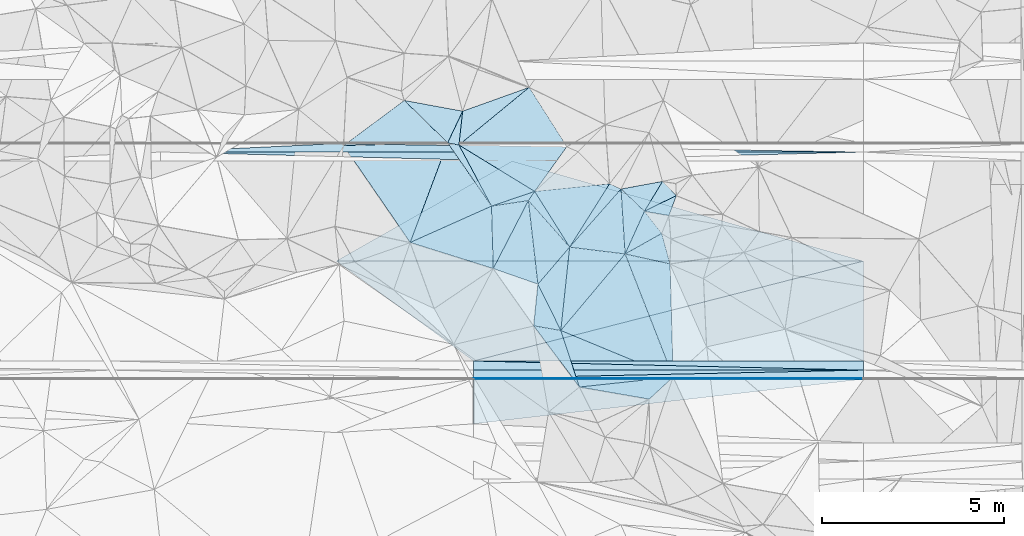
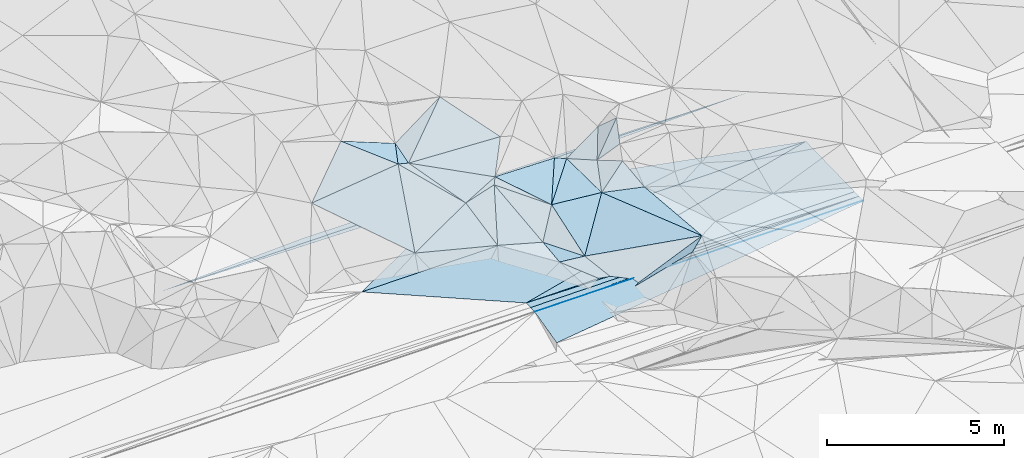
# One storey, part 50 of 275: 45 plates.
"""IFC2X3 building model written with IfcOpenShell, lengths in millimetres."""

from ifc_helpers import new_model, si_unit, frame, origin_with_axes, place, context, subcontext, project, spatial, polyline, outline, extrude, material, type_object, element, save


model = new_model("IFC2X3")

# Units and contexts
model_context = context("Model", 3, precision=1e-05, world=origin_with_axes())
body_context = subcontext(model_context, "Body", "Model", "MODEL_VIEW")
ifc_project = project(units=[si_unit("LENGTHUNIT", "METRE", prefix="MILLI"), si_unit("AREAUNIT", "SQUARE_METRE"), si_unit("VOLUMEUNIT", "CUBIC_METRE"), si_unit("MASSUNIT", "GRAM", prefix="KILO"), si_unit("TIMEUNIT", "SECOND"), si_unit("PLANEANGLEUNIT", "RADIAN"), si_unit("SOLIDANGLEUNIT", "STERADIAN"), si_unit("THERMODYNAMICTEMPERATUREUNIT", "DEGREE_CELSIUS"), si_unit("LUMINOUSINTENSITYUNIT", "LUMEN")], contexts=[model_context])

# Site, building, storey
site_placement = place(None, origin_with_axes())
site = spatial("IfcSite", under=ifc_project, at=site_placement, CompositionType="ELEMENT")
building_placement = place(site_placement, origin_with_axes())
building = spatial("IfcBuilding", under=site, at=building_placement, Name="Undefined", CompositionType="ELEMENT")
storey_placement = place(building_placement, origin_with_axes())
storey = spatial("IfcBuildingStorey", under=building, at=storey_placement, Name="Undefined", CompositionType="ELEMENT", Elevation=0.0)

# Plates
ifc_material = material()
plate_type_1 = type_object("IfcPlateType", PredefinedType="NOTDEFINED")
plate_1_placement = place(storey_placement, frame((-124610.502362477, 63294.0443863483, 49008.9291654633), z_axis=(0.008324340579686, 0.024990848492353, -0.999653021225638), x_axis=(0.999965340787191, -5.73519775278889e-05, 0.0083254990906575)))
element("IfcPlate", 1, at=plate_1_placement, inside=storey, type_object=plate_type_1, material=ifc_material, Name="00_PR", context=body_context, shape_type="SweptSolid", body=[
    extrude(outline(polyline([(0.0, 0.0), (14503.03515625, 1.02263584267348e-07), (3779.63134765625, 2750.85864257813), (0.0, 0.0)])), frame((-8.85201319254618e-08, 2.18876761149539e-07, -0.5000001331573), z_axis=(0.0, 0.0, 1.0), x_axis=(1.0, 0.0, 0.0)), (0.0, 0.0, 1.0), 1.0),
])
plate_2_placement = place(storey_placement, frame((-120830.587315527, 60543.8280489618, 48971.6511662542), z_axis=(0.008324340579686, 0.024990848492353, -0.999653021225638), x_axis=(0.968565278490692, 0.248349656151851, 0.0142740881147066)))
element("IfcPlate", 2, at=plate_2_placement, inside=storey, type_object=plate_type_1, material=ifc_material, Name="00_PR", context=body_context, shape_type="SweptSolid", body=[
    extrude(outline(polyline([(0.0, 0.0), (11070.619140625, -4.8195943236351e-08), (10386.5244140625, 2664.43994140625), (0.0, 0.0)])), frame((-8.85201319254618e-08, 2.18876761149539e-07, -0.5000001331573), z_axis=(0.0, 0.0, 1.0), x_axis=(1.0, 0.0, 0.0)), (0.0, 0.0, 1.0), 1.0),
])
plate_3_placement = place(storey_placement, frame((-119776.166734468, 66043.7427297711, 48980.4271662069), z_axis=(0.00832149793297365, -0.0249918019511436, -0.9996530210565), x_axis=(0.96172712039003, -0.273606547074793, 0.0148459861279161)))
element("IfcPlate", 3, at=plate_3_placement, inside=storey, type_object=plate_type_1, material=ifc_material, Name="00_PR", context=body_context, shape_type="SweptSolid", body=[
    extrude(outline(polyline([(0.0, 0.0), (10052.953125, -1.1648444342427e-07), (-3896.54565429688, 3968.56689453125), (0.0, 0.0)])), frame((-8.85201319254618e-08, 2.18876761149539e-07, -0.5000001331573), z_axis=(0.0, 0.0, 1.0), x_axis=(1.0, 0.0, 0.0)), (0.0, 0.0, 1.0), 1.0),
])
plate_type_2 = type_object("IfcPlateType", PredefinedType="NOTDEFINED")
plate_4_placement = place(storey_placement, frame((-110108.127132819, 60543.212590805, 49060.924166967), z_axis=(0.008324340579686, 0.024990848492353, -0.999653021225638), x_axis=(-5.72779639714365e-05, -0.999687644771442, -0.0249921909916474)))
element("IfcPlate", 4, at=plate_4_placement, inside=storey, type_object=plate_type_2, material=ifc_material, Name="00_PR", context=body_context, shape_type="SweptSolid", body=[
    extrude(outline(polyline([(0.0, 0.0), (250.078109741211, 1.02591002359986e-09), (2.2299907207489, 10722.83203125), (0.0, 0.0)])), frame((-8.85201319254618e-08, 2.18876761149539e-07, -0.5000001331573), z_axis=(0.0, 0.0, 1.0), x_axis=(1.0, 0.0, 0.0)), (0.0, 0.0, 1.0), 1.0),
])
plate_5_placement = place(storey_placement, frame((-110108.14145708, 60293.2125942532, 49054.6741678356), z_axis=(0.00832424080938101, 0.0250068329668296, -0.999652622324334), x_axis=(-0.999965344853481, 5.72919765649429e-05, -0.00832501109232228)))
element("IfcPlate", 5, at=plate_5_placement, inside=storey, type_object=plate_type_2, material=ifc_material, Name="00_PR", context=body_context, shape_type="SweptSolid", body=[
    extrude(outline(polyline([(0.0, 0.0), (10722.83203125, -5.55592123419046e-08), (10722.7802734375, 250.078216552734), (0.0, 0.0)])), frame((-8.85201319254618e-08, 2.18876761149539e-07, -0.5000001331573), z_axis=(0.0, 0.0, 1.0), x_axis=(1.0, 0.0, 0.0)), (0.0, 0.0, 1.0), 1.0),
])
plate_6_placement = place(storey_placement, frame((-129444.507635454, 66294.2964973411, 48893.6811645161), z_axis=(0.00832144820991533, -0.0249898612840356, -0.99965306998613), x_axis=(0.999965340787191, -5.73519775278889e-05, 0.0083254990906575)))
element("IfcPlate", 6, at=plate_6_placement, inside=storey, type_object=plate_type_2, material=ifc_material, Name="00_PR", context=body_context, shape_type="SweptSolid", body=[
    extrude(outline(polyline([(0.0, 0.0), (19337.380859375, 2.13287421502173e-07), (9668.7421875, 250.077438354492), (0.0, 0.0)])), frame((-8.85201319254618e-08, 2.18876761149539e-07, -0.5000001331573), z_axis=(0.0, 0.0, 1.0), x_axis=(1.0, 0.0, 0.0)), (0.0, 0.0, 1.0), 1.0),
])
plate_type_3 = type_object("IfcPlateType", PredefinedType="NOTDEFINED")
plate_7_placement = place(storey_placement, frame((-120830.61538651, 60063.8395127007, 48953.8976337332), z_axis=(0.00831835231018961, 0.0499346274362642, -0.998717847040717), x_axis=(0.999965340787191, -5.73519775278889e-05, 0.0083254990906575)))
element("IfcPlate", 7, at=plate_7_placement, inside=storey, type_object=plate_type_3, material=ifc_material, Name="00_PR", context=body_context, shape_type="SweptSolid", body=[
    extrude(outline(polyline([(0.0, 0.0), (10722.83203125, -5.55592123419046e-08), (10722.82421875, 20.0253067016602), (0.0, 0.0)])), frame((-8.85201319254618e-08, 2.18876761149539e-07, -0.5000001331573), z_axis=(0.0, 0.0, 1.0), x_axis=(1.0, 0.0, 0.0)), (0.0, 0.0, 1.0), 1.0),
])
plate_8_placement = place(storey_placement, frame((-110108.155782684, 60043.2248544637, 49042.1746248938), z_axis=(0.00831779862514196, 0.049539601639022, -0.998737524125072), x_axis=(-0.999965344853481, 5.72919765649429e-05, -0.00832501109232228)))
element("IfcPlate", 8, at=plate_8_placement, inside=storey, type_object=plate_type_3, material=ifc_material, Name="00_PR", context=body_context, shape_type="SweptSolid", body=[
    extrude(outline(polyline([(0.0, 0.0), (10722.83203125, -5.55592123419046e-08), (10722.82421875, 20.0235919952393), (0.0, 0.0)])), frame((-8.85201319254618e-08, 2.18876761149539e-07, -0.5000001331573), z_axis=(0.0, 0.0, 1.0), x_axis=(1.0, 0.0, 0.0)), (0.0, 0.0, 1.0), 1.0),
])
plate_type_4 = type_object("IfcPlateType", PredefinedType="NOTDEFINED")
plate_9_placement = place(storey_placement, frame((-110108.154697284, 60063.2253811609, 49043.1746351138), z_axis=(0.00831835231018961, 0.0499346274362642, -0.998717847040717), x_axis=(-0.999965344853481, 5.72919765649429e-05, -0.00832501109232228)))
element("IfcPlate", 9, at=plate_9_placement, inside=storey, type_object=plate_type_4, material=ifc_material, Name="00_PR", context=body_context, shape_type="SweptSolid", body=[
    extrude(outline(polyline([(0.0, 0.0), (10722.83203125, -5.55592123419046e-08), (-0.0958082377910614, 230.286972045898), (0.0, 0.0)])), frame((-8.85201319254618e-08, 2.18876761149539e-07, -0.5000001331573), z_axis=(0.0, 0.0, 1.0), x_axis=(1.0, 0.0, 0.0)), (0.0, 0.0, 1.0), 1.0),
])
plate_10_placement = place(storey_placement, frame((-120830.601646001, 60293.8405085212, 48965.3976334797), z_axis=(0.00831835231018961, 0.0499346274362642, -0.998717847040717), x_axis=(0.999965340787191, -5.73519775278889e-05, 0.0083254990906575)))
element("IfcPlate", 10, at=plate_10_placement, inside=storey, type_object=plate_type_4, material=ifc_material, Name="00_PR", context=body_context, shape_type="SweptSolid", body=[
    extrude(outline(polyline([(0.0, 0.0), (10722.83203125, -5.55592123419046e-08), (-0.0962902829051018, 230.288299560547), (0.0, 0.0)])), frame((-8.85201319254618e-08, 2.18876761149539e-07, -0.5000001331573), z_axis=(0.0, 0.0, 1.0), x_axis=(1.0, 0.0, 0.0)), (0.0, 0.0, 1.0), 1.0),
])
plate_11_placement = place(storey_placement, frame((-110107.797697008, 66293.1751613901, 49054.6746353648), z_axis=(0.00831224750610881, -0.0499379782776763, -0.998717730325709), x_axis=(-0.999965344853481, 5.72919765649429e-05, -0.00832501109232228)))
element("IfcPlate", 11, at=plate_11_placement, inside=storey, type_object=plate_type_4, material=ifc_material, Name="00_PR", context=body_context, shape_type="SweptSolid", body=[
    extrude(outline(polyline([(0.0, 0.0), (19337.380859375, 2.13287421502173e-07), (14503.130859375, 230.287124633789), (0.0, 0.0)])), frame((-8.85201319254618e-08, 2.18876761149539e-07, -0.5000001331573), z_axis=(0.0, 0.0, 1.0), x_axis=(1.0, 0.0, 0.0)), (0.0, 0.0, 1.0), 1.0),
])
plate_type_5 = type_object("IfcPlateType", PredefinedType="NOTDEFINED")
plate_12_placement = place(storey_placement, frame((-119325.093733109, 64958.7979424219, 49849.5225955544), z_axis=(0.066211966406673, 0.289808461752004, -0.954791616532895), x_axis=(0.652565308022866, -0.73645985067863, -0.178284623855879)))
element("IfcPlate", 12, at=plate_12_placement, inside=storey, type_object=plate_type_5, material=ifc_material, Name="00", context=body_context, shape_type="SweptSolid", body=[
    extrude(outline(polyline([(0.0, 0.0), (1738.79272460938, -3.34694050252438e-10), (1986.60827636719, 1369.66687011719), (0.0, 0.0)])), frame((-8.85201319254618e-08, 2.18876761149539e-07, -0.5000001331573), z_axis=(0.0, 0.0, 1.0), x_axis=(1.0, 0.0, 0.0)), (0.0, 0.0, 1.0), 1.0),
])
plate_type_6 = type_object("IfcPlateType", PredefinedType="NOTDEFINED")
plate_13_placement = place(storey_placement, frame((-121546.665615824, 66546.1144424768, 50379.5313573619), z_axis=(-0.0547410617611769, 0.344343148468041, -0.937246612296025), x_axis=(0.974375206189065, -0.186667956876011, -0.125491160803271)))
element("IfcPlate", 13, at=plate_13_placement, inside=storey, type_object=plate_type_6, material=ifc_material, Name="00", context=body_context, shape_type="SweptSolid", body=[
    extrude(outline(polyline([(0.0, 0.0), (318.74755859375, 6.03904481977224e-10), (1589.97302246094, 1569.23095703125), (0.0, 0.0)])), frame((-8.85201319254618e-08, 2.18876761149539e-07, -0.5000001331573), z_axis=(0.0, 0.0, 1.0), x_axis=(1.0, 0.0, 0.0)), (0.0, 0.0, 1.0), 1.0),
])
plate_type_7 = type_object("IfcPlateType", PredefinedType="NOTDEFINED")
plate_14_placement = place(storey_placement, frame((-116133.093025118, 64664.0184016748, 49759.6508206451), z_axis=(0.715528851747422, -0.0190819038643633, -0.69832252094711), x_axis=(0.46304293591163, 0.761444101335042, 0.453645368150507)))
element("IfcPlate", 14, at=plate_14_placement, inside=storey, type_object=plate_type_7, material=ifc_material, Name="00", context=body_context, shape_type="SweptSolid", body=[
    extrude(outline(polyline([(0.0, 0.0), (1080.13891601563, 5.29689714312553e-09), (1140.87182617188, 672.689758300781), (0.0, 0.0)])), frame((-8.85201319254618e-08, 2.18876761149539e-07, -0.5000001331573), z_axis=(0.0, 0.0, 1.0), x_axis=(1.0, 0.0, 0.0)), (0.0, 0.0, 1.0), 1.0),
])
plate_type_8 = type_object("IfcPlateType", PredefinedType="NOTDEFINED")
plate_15_placement = place(storey_placement, frame((-120830.687312707, 58815.2346338975, 48645.7449369341), z_axis=(0.0080904527200821, 0.242527248972756, -0.970110858655077), x_axis=(5.62409505467911e-05, 0.970142599249694, 0.242535222097746)))
element("IfcPlate", 15, at=plate_15_placement, inside=storey, type_object=plate_type_8, material=ifc_material, Name="00_PR", context=body_context, shape_type="SweptSolid", body=[
    extrude(outline(polyline([(0.0, 0.0), (1266.51708984375, -2.38651409745216e-09), (1288.17395019531, 10722.8095703125), (0.0, 0.0)])), frame((-8.85201319254618e-08, 2.18876761149539e-07, -0.5000001331573), z_axis=(0.0, 0.0, 1.0), x_axis=(1.0, 0.0, 0.0)), (0.0, 0.0, 1.0), 1.0),
])
plate_type_9 = type_object("IfcPlateType", PredefinedType="NOTDEFINED")
plate_16_placement = place(storey_placement, frame((-117091.49939466, 65421.3958546623, 49709.505641668), z_axis=(-0.0629014861596609, 0.136073393855939, -0.988699870801768), x_axis=(0.90287237307785, -0.414388060820088, -0.114472760875842)))
element("IfcPlate", 16, at=plate_16_placement, inside=storey, type_object=plate_type_9, material=ifc_material, Name="00", context=body_context, shape_type="SweptSolid", body=[
    extrude(outline(polyline([(0.0, 0.0), (349.428100585938, -4.64206095784903e-09), (-250.409164428711, 2052.50952148438), (0.0, 0.0)])), frame((-8.85201319254618e-08, 2.18876761149539e-07, -0.5000001331573), z_axis=(0.0, 0.0, 1.0), x_axis=(1.0, 0.0, 0.0)), (0.0, 0.0, 1.0), 1.0),
])
plate_type_10 = type_object("IfcPlateType", PredefinedType="NOTDEFINED")
plate_17_placement = place(storey_placement, frame((-115427.55023687, 63216.0212884442, 49469.5682371401), z_axis=(0.0618532587491814, 0.500524877992993, -0.86350971094262), x_axis=(-0.974894500019316, 0.2157152547801, 0.0552054588536712)))
element("IfcPlate", 17, at=plate_17_placement, inside=storey, type_object=plate_type_10, material=ifc_material, Name="00", context=body_context, shape_type="SweptSolid", body=[
    extrude(outline(polyline([(0.0, 0.0), (1267.99047851563, -5.28962118551135e-09), (430.050537109375, 890.200256347656), (0.0, 0.0)])), frame((-8.85201319254618e-08, 2.18876761149539e-07, -0.5000001331573), z_axis=(0.0, 0.0, 1.0), x_axis=(1.0, 0.0, 0.0)), (0.0, 0.0, 1.0), 1.0),
])
plate_type_11 = type_object("IfcPlateType", PredefinedType="NOTDEFINED")
plate_18_placement = place(storey_placement, frame((-116775.87064154, 65276.5711588291, 49669.5136918065), z_axis=(0.216642370821797, 0.0843505736027305, -0.972600156229476), x_axis=(0.720125798164282, -0.686472310904861, 0.100869228108457)))
element("IfcPlate", 18, at=plate_18_placement, inside=storey, type_object=plate_type_11, material=ifc_material, Name="00", context=body_context, shape_type="SweptSolid", body=[
    extrude(outline(polyline([(0.0, 0.0), (892.244384765625, 4.48926584795117e-09), (1294.60046386719, 1244.06970214844), (0.0, 0.0)])), frame((-8.85201319254618e-08, 2.18876761149539e-07, -0.5000001331573), z_axis=(0.0, 0.0, 1.0), x_axis=(1.0, 0.0, 0.0)), (0.0, 0.0, 1.0), 1.0),
])
plate_type_12 = type_object("IfcPlateType", PredefinedType="NOTDEFINED")
plate_19_placement = place(storey_placement, frame((-116663.733641182, 63489.332487826, 49539.5013407778), z_axis=(0.00904118606762447, 0.0731083068044699, -0.997283025239412), x_axis=(-0.992439676174179, 0.122733406843003, -2.11121228579398e-10)))
element("IfcPlate", 19, at=plate_19_placement, inside=storey, type_object=plate_type_12, material=ifc_material, Name="00", context=body_context, shape_type="SweptSolid", body=[
    extrude(outline(polyline([(0.0, 0.0), (1538.34326171875, -8.79663275554776e-09), (330.745422363281, 1764.74011230469), (0.0, 0.0)])), frame((-8.85201319254618e-08, 2.18876761149539e-07, -0.5000001331573), z_axis=(0.0, 0.0, 1.0), x_axis=(1.0, 0.0, 0.0)), (0.0, 0.0, 1.0), 1.0),
])
plate_type_13 = type_object("IfcPlateType", PredefinedType="NOTDEFINED")
plate_20_placement = place(storey_placement, frame((-121546.760462126, 66546.0221391505, 50379.5217716897), z_axis=(-0.244435305868527, 0.159737043963881, -0.956418035186832), x_axis=(-0.685034322359886, 0.669632130091373, 0.286915993869674)))
element("IfcPlate", 20, at=plate_20_placement, inside=storey, type_object=plate_type_13, material=ifc_material, Name="00", context=body_context, shape_type="SweptSolid", body=[
    extrude(outline(polyline([(0.0, 0.0), (1742.67041015625, 5.52245182916522e-09), (312.107208251953, 913.230041503906), (0.0, 0.0)])), frame((-8.85201319254618e-08, 2.18876761149539e-07, -0.5000001331573), z_axis=(0.0, 0.0, 1.0), x_axis=(1.0, 0.0, 0.0)), (0.0, 0.0, 1.0), 1.0),
])
plate_type_14 = type_object("IfcPlateType", PredefinedType="NOTDEFINED")
plate_21_placement = place(storey_placement, frame((-121236.032806877, 66486.6389579041, 50339.5409918523), z_axis=(0.0514480909433046, 0.393278622209551, -0.91797876840984), x_axis=(0.839879183112936, -0.514366198870355, -0.173292732776682)))
element("IfcPlate", 21, at=plate_21_placement, inside=storey, type_object=plate_type_14, material=ifc_material, Name="00", context=body_context, shape_type="SweptSolid", body=[
    extrude(outline(polyline([(0.0, 0.0), (2481.35034179688, -9.17862053029239e-09), (1733.61242675781, 1035.89953613281), (0.0, 0.0)])), frame((-8.85201319254618e-08, 2.18876761149539e-07, -0.5000001331573), z_axis=(0.0, 0.0, 1.0), x_axis=(1.0, 0.0, 0.0)), (0.0, 0.0, 1.0), 1.0),
])
plate_type_15 = type_object("IfcPlateType", PredefinedType="NOTDEFINED")
plate_22_placement = place(storey_placement, frame((-119179.551573836, 61513.4325413866, 49219.521852626), z_axis=(0.0746911852359752, 0.282819372774868, -0.956260649211958), x_axis=(0.984945082818069, -0.170838974789615, 0.0264050852174407)))
element("IfcPlate", 22, at=plate_22_placement, inside=storey, type_object=plate_type_15, material=ifc_material, Name="00", context=body_context, shape_type="SweptSolid", body=[
    extrude(outline(polyline([(0.0, 0.0), (757.429870605469, -4.15457179769874e-09), (1517.10412597656, 1510.56115722656), (0.0, 0.0)])), frame((-8.85201319254618e-08, 2.18876761149539e-07, -0.5000001331573), z_axis=(0.0, 0.0, 1.0), x_axis=(1.0, 0.0, 0.0)), (0.0, 0.0, 1.0), 1.0),
])
plate_type_16 = type_object("IfcPlateType", PredefinedType="NOTDEFINED")
plate_23_placement = place(storey_placement, frame((-124411.041466209, 66471.5840694024, 50079.5581231795), z_axis=(0.0805481094220166, 0.461044029652685, -0.883713983588668), x_axis=(0.749202544692307, 0.55676534906545, 0.358758823036591)))
element("IfcPlate", 23, at=plate_23_placement, inside=storey, type_object=plate_type_16, material=ifc_material, Name="00", context=body_context, shape_type="SweptSolid", body=[
    extrude(outline(polyline([(0.0, 0.0), (2229.91040039063, 3.05590219795704e-09), (2295.20434570313, 1741.44677734375), (0.0, 0.0)])), frame((-8.85201319254618e-08, 2.18876761149539e-07, -0.5000001331573), z_axis=(0.0, 0.0, 1.0), x_axis=(1.0, 0.0, 0.0)), (0.0, 0.0, 1.0), 1.0),
])
plate_type_17 = type_object("IfcPlateType", PredefinedType="NOTDEFINED")
plate_24_placement = place(storey_placement, frame((-118265.247324331, 66444.1957557585, 50239.5197992074), z_axis=(-0.0283718773315375, 0.277231736320905, -0.96038409032698), x_axis=(-0.570298220555847, -0.793549529743997, -0.212224134993916)))
element("IfcPlate", 24, at=plate_24_placement, inside=storey, type_object=plate_type_17, material=ifc_material, Name="00", context=body_context, shape_type="SweptSolid", body=[
    extrude(outline(polyline([(0.0, 0.0), (1554.95983886719, 1.07684172689915e-08), (1639.39929199219, 2479.91333007813), (0.0, 0.0)])), frame((-8.85201319254618e-08, 2.18876761149539e-07, -0.5000001331573), z_axis=(0.0, 0.0, 1.0), x_axis=(1.0, 0.0, 0.0)), (0.0, 0.0, 1.0), 1.0),
])
plate_type_18 = type_object("IfcPlateType", PredefinedType="NOTDEFINED")
plate_25_placement = place(storey_placement, frame((-116663.556073959, 63489.3009321919, 49539.534354562), z_axis=(0.364181895290088, 0.0100101350827713, -0.931274043629771), x_axis=(0.405568333011107, 0.898445107584856, 0.168257885150829)))
element("IfcPlate", 25, at=plate_25_placement, inside=storey, type_object=plate_type_18, material=ifc_material, Name="00", context=body_context, shape_type="SweptSolid", body=[
    extrude(outline(polyline([(0.0, 0.0), (1307.51672363281, -2.12457962334156e-09), (984.002685546875, 725.492004394531), (0.0, 0.0)])), frame((-8.85201319254618e-08, 2.18876761149539e-07, -0.5000001331573), z_axis=(0.0, 0.0, 1.0), x_axis=(1.0, 0.0, 0.0)), (0.0, 0.0, 1.0), 1.0),
])
plate_type_19 = type_object("IfcPlateType", PredefinedType="NOTDEFINED")
plate_26_placement = place(storey_placement, frame((-119152.025029337, 65210.2362615342, 49909.5138124331), z_axis=(-0.00215097992596716, 0.233485643640575, -0.97235787007619), x_axis=(0.52082784441825, -0.82980433821746, -0.200407376995266)))
element("IfcPlate", 26, at=plate_26_placement, inside=storey, type_object=plate_type_19, material=ifc_material, Name="00", context=body_context, shape_type="SweptSolid", body=[
    extrude(outline(polyline([(0.0, 0.0), (1846.23937988281, 5.60976332053542e-09), (130.535614013672, 282.4189453125), (0.0, 0.0)])), frame((-8.85201319254618e-08, 2.18876761149539e-07, -0.5000001331573), z_axis=(0.0, 0.0, 1.0), x_axis=(1.0, 0.0, 0.0)), (0.0, 0.0, 1.0), 1.0),
])
plate_type_20 = type_object("IfcPlateType", PredefinedType="NOTDEFINED")
plate_27_placement = place(storey_placement, frame((-118433.55418538, 61383.9565814811, 49239.5041673636), z_axis=(0.0158288827857986, 0.127994584769335, -0.99164854295233), x_axis=(0.104497458809963, 0.986129862443978, 0.128950283049246)))
element("IfcPlate", 27, at=plate_27_placement, inside=storey, type_object=plate_type_20, material=ifc_material, Name="00", context=body_context, shape_type="SweptSolid", body=[
    extrude(outline(polyline([(0.0, 0.0), (2326.47802734375, -6.22821971774101e-09), (2299.82836914063, 1538.11242675781), (0.0, 0.0)])), frame((-8.85201319254618e-08, 2.18876761149539e-07, -0.5000001331573), z_axis=(0.0, 0.0, 1.0), x_axis=(1.0, 0.0, 0.0)), (0.0, 0.0, 1.0), 1.0),
])
plate_type_21 = type_object("IfcPlateType", PredefinedType="NOTDEFINED")
plate_28_placement = place(storey_placement, frame((-119062.579258319, 62658.5185209833, 49169.522063369), z_axis=(0.054350700857574, 0.288769086901119, -0.955854808936266), x_axis=(-0.942901871517309, 0.32987295897065, 0.0460422808851249)))
element("IfcPlate", 28, at=plate_28_placement, inside=storey, type_object=plate_type_21, material=ifc_material, Name="00", context=body_context, shape_type="SweptSolid", body=[
    extrude(outline(polyline([(0.0, 0.0), (1303.15002441406, -8.92032403498888e-09), (1037.63952636719, 2178.50952148438), (0.0, 0.0)])), frame((-8.85201319254618e-08, 2.18876761149539e-07, -0.5000001331573), z_axis=(0.0, 0.0, 1.0), x_axis=(1.0, 0.0, 0.0)), (0.0, 0.0, 1.0), 1.0),
])
plate_type_22 = type_object("IfcPlateType", PredefinedType="NOTDEFINED")
plate_29_placement = place(storey_placement, frame((-118433.414813702, 61383.9391662039, 49239.5244436526), z_axis=(0.294568313296682, 0.0931523621219417, -0.951079463679377), x_axis=(-0.442058215299041, 0.895636456230213, -0.0491922001745405)))
element("IfcPlate", 29, at=plate_29_placement, inside=storey, type_object=plate_type_22, material=ifc_material, Name="00", context=body_context, shape_type="SweptSolid", body=[
    extrude(outline(polyline([(0.0, 0.0), (1422.98986816406, -1.76078174263239e-09), (1932.55078125, 1295.27905273438), (0.0, 0.0)])), frame((-8.85201319254618e-08, 2.18876761149539e-07, -0.5000001331573), z_axis=(0.0, 0.0, 1.0), x_axis=(1.0, 0.0, 0.0)), (0.0, 0.0, 1.0), 1.0),
])
plate_type_23 = type_object("IfcPlateType", PredefinedType="NOTDEFINED")
plate_30_placement = place(storey_placement, frame((-120339.683418775, 64805.3605008986, 49669.5101215499), z_axis=(0.154557836693083, 0.127372524662643, -0.979738799414323), x_axis=(0.929680037747538, 0.316867850104629, 0.187855777083929)))
element("IfcPlate", 30, at=plate_30_placement, inside=storey, type_object=plate_type_23, material=ifc_material, Name="00", context=body_context, shape_type="SweptSolid", body=[
    extrude(outline(polyline([(0.0, 0.0), (1277.57580566406, 4.17639967054129e-09), (1025.69250488281, 182.632995605469), (0.0, 0.0)])), frame((-8.85201319254618e-08, 2.18876761149539e-07, -0.5000001331573), z_axis=(0.0, 0.0, 1.0), x_axis=(1.0, 0.0, 0.0)), (0.0, 0.0, 1.0), 1.0),
])
plate_type_24 = type_object("IfcPlateType", PredefinedType="NOTDEFINED")
plate_31_placement = place(storey_placement, frame((-122576.486897287, 63805.6334441782, 49329.5160728864), z_axis=(0.0358091539897892, 0.249021091751864, -0.967835833369092), x_axis=(0.904283208720706, 0.40419974308369, 0.137457070086854)))
element("IfcPlate", 31, at=plate_31_placement, inside=storey, type_object=plate_type_24, material=ifc_material, Name="00", context=body_context, shape_type="SweptSolid", body=[
    extrude(outline(polyline([(0.0, 0.0), (2473.49951171875, 4.56930138170719e-09), (1762.765625, 1624.517578125), (0.0, 0.0)])), frame((-8.85201319254618e-08, 2.18876761149539e-07, -0.5000001331573), z_axis=(0.0, 0.0, 1.0), x_axis=(1.0, 0.0, 0.0)), (0.0, 0.0, 1.0), 1.0),
])
plate_type_25 = type_object("IfcPlateType", PredefinedType="NOTDEFINED")
plate_32_placement = place(storey_placement, frame((-115342.149849025, 60104.377194819, 49639.5698029977), z_axis=(0.316407381633033, -0.399543881177956, -0.860378437585104), x_axis=(-0.734323527940562, -0.677339832206832, 0.0444939099085128)))
element("IfcPlate", 32, at=plate_32_placement, inside=storey, type_object=plate_type_25, material=ifc_material, Name="00", context=body_context, shape_type="SweptSolid", body=[
    extrude(outline(polyline([(0.0, 0.0), (898.999450683594, 4.08908817917109e-09), (2044.05017089844, 1794.22924804688), (0.0, 0.0)])), frame((-8.85201319254618e-08, 2.18876761149539e-07, -0.5000001331573), z_axis=(0.0, 0.0, 1.0), x_axis=(1.0, 0.0, 0.0)), (0.0, 0.0, 1.0), 1.0),
])
plate_type_26 = type_object("IfcPlateType", PredefinedType="NOTDEFINED")
plate_33_placement = place(storey_placement, frame((-121235.918569406, 66486.4681206944, 50339.5206653885), z_axis=(0.279934771929813, 0.0516074239456176, -0.958630897300051), x_axis=(0.108892167807436, 0.990402826945736, 0.0851160159317348)))
element("IfcPlate", 33, at=plate_33_placement, inside=storey, type_object=plate_type_26, material=ifc_material, Name="00", context=body_context, shape_type="SweptSolid", body=[
    extrude(outline(polyline([(0.0, 0.0), (939.893615722656, -1.87719706445932e-09), (1837.86755371094, 1817.06982421875), (0.0, 0.0)])), frame((-8.85201319254618e-08, 2.18876761149539e-07, -0.5000001331573), z_axis=(0.0, 0.0, 1.0), x_axis=(1.0, 0.0, 0.0)), (0.0, 0.0, 1.0), 1.0),
])
plate_type_27 = type_object("IfcPlateType", PredefinedType="NOTDEFINED")
plate_34_placement = place(storey_placement, frame((-121133.765900852, 67417.3641021398, 50419.5053221043), z_axis=(-0.108834709776785, 0.0969887895225073, -0.989317027375331), x_axis=(-0.108892167821664, -0.990402826945935, -0.0851160159112202)))
element("IfcPlate", 34, at=plate_34_placement, inside=storey, type_object=plate_type_27, material=ifc_material, Name="00", context=body_context, shape_type="SweptSolid", body=[
    extrude(outline(polyline([(0.0, 0.0), (939.893615722656, -1.87719706445932e-09), (911.379760742188, 317.469635009766), (0.0, 0.0)])), frame((-8.85201319254618e-08, 2.18876761149539e-07, -0.5000001331573), z_axis=(0.0, 0.0, 1.0), x_axis=(1.0, 0.0, 0.0)), (0.0, 0.0, 1.0), 1.0),
])
plate_type_28 = type_object("IfcPlateType", PredefinedType="NOTDEFINED")
plate_35_placement = place(storey_placement, frame((-117920.692207946, 59828.5525779845, 48819.5452592751), z_axis=(0.253947426768248, 0.329267678791098, -0.909446809957189), x_axis=(-0.3032495650492, 0.919966112507811, 0.248398979737712)))
element("IfcPlate", 35, at=plate_35_placement, inside=storey, type_object=plate_type_28, material=ifc_material, Name="00", context=body_context, shape_type="SweptSolid", body=[
    extrude(outline(polyline([(0.0, 0.0), (1690.82824707031, -3.79804987460375e-09), (-324.160675048828, 2700.4296875), (0.0, 0.0)])), frame((-8.85201319254618e-08, 2.18876761149539e-07, -0.5000001331573), z_axis=(0.0, 0.0, 1.0), x_axis=(1.0, 0.0, 0.0)), (0.0, 0.0, 1.0), 1.0),
])
plate_type_29 = type_object("IfcPlateType", PredefinedType="NOTDEFINED")
plate_36_placement = place(storey_placement, frame((-115342.238876759, 60104.589353787, 49639.5049479321), z_axis=(0.138362456978983, 0.0247669370759464, -0.990071931390147), x_axis=(-0.917463808881891, 0.379692437779503, -0.118717362188485)))
element("IfcPlate", 36, at=plate_36_placement, inside=storey, type_object=plate_type_29, material=ifc_material, Name="00", context=body_context, shape_type="SweptSolid", body=[
    extrude(outline(polyline([(0.0, 0.0), (3369.34716796875, -5.37693267688155e-09), (2509.38818359375, 2629.72827148438), (0.0, 0.0)])), frame((-8.85201319254618e-08, 2.18876761149539e-07, -0.5000001331573), z_axis=(0.0, 0.0, 1.0), x_axis=(1.0, 0.0, 0.0)), (0.0, 0.0, 1.0), 1.0),
])
plate_type_30 = type_object("IfcPlateType", PredefinedType="NOTDEFINED")
plate_37_placement = place(storey_placement, frame((-119062.596995141, 62658.3513707881, 49169.5005909317), z_axis=(0.018877104369261, -0.0455403632812358, -0.998784125946566), x_axis=(0.442058215297751, -0.895636456230992, 0.0491922001719633)))
element("IfcPlate", 37, at=plate_37_placement, inside=storey, type_object=plate_type_30, material=ifc_material, Name="00", context=body_context, shape_type="SweptSolid", body=[
    extrude(outline(polyline([(0.0, 0.0), (1422.98986816406, -1.76078174263239e-09), (976.324645996094, 611.710876464844), (0.0, 0.0)])), frame((-8.85201319254618e-08, 2.18876761149539e-07, -0.5000001331573), z_axis=(0.0, 0.0, 1.0), x_axis=(1.0, 0.0, 0.0)), (0.0, 0.0, 1.0), 1.0),
])
plate_type_31 = type_object("IfcPlateType", PredefinedType="NOTDEFINED")
plate_38_placement = place(storey_placement, frame((-118190.507120944, 63678.1851589308, 49539.5101366588), z_axis=(-0.112128588919325, 0.166229153643388, -0.979691302414166), x_axis=(-0.520827844391641, 0.82980433825455, 0.200407376910846)))
element("IfcPlate", 38, at=plate_38_placement, inside=storey, type_object=plate_type_31, material=ifc_material, Name="00", context=body_context, shape_type="SweptSolid", body=[
    extrude(outline(polyline([(0.0, 0.0), (1846.23937988281, 5.60976332053542e-09), (908.224548339844, 1857.58666992188), (0.0, 0.0)])), frame((-8.85201319254618e-08, 2.18876761149539e-07, -0.5000001331573), z_axis=(0.0, 0.0, 1.0), x_axis=(1.0, 0.0, 0.0)), (0.0, 0.0, 1.0), 1.0),
])
plate_type_32 = type_object("IfcPlateType", PredefinedType="NOTDEFINED")
plate_39_placement = place(storey_placement, frame((-120291.282803755, 63088.3728714237, 49229.520351526), z_axis=(0.13245863636782, 0.249548569218346, -0.959260246884366), x_axis=(-0.0273020291982286, 0.968339252508485, 0.248140466778331)))
element("IfcPlate", 39, at=plate_39_placement, inside=storey, type_object=plate_type_32, material=ifc_material, Name="00", context=body_context, shape_type="SweptSolid", body=[
    extrude(outline(polyline([(0.0, 0.0), (1773.18920898438, 4.22005541622639e-09), (1938.65380859375, 1028.60168457031), (0.0, 0.0)])), frame((-8.85201319254618e-08, 2.18876761149539e-07, -0.5000001331573), z_axis=(0.0, 0.0, 1.0), x_axis=(1.0, 0.0, 0.0)), (0.0, 0.0, 1.0), 1.0),
])
plate_type_33 = type_object("IfcPlateType", PredefinedType="NOTDEFINED")
plate_40_placement = place(storey_placement, frame((-124411.036716085, 66471.5168735828, 50079.5295573016), z_axis=(0.0900312578109312, 0.32665232460906, -0.940846762998353), x_axis=(0.994226915809279, 0.0258891881834163, 0.104127757181132)))
element("IfcPlate", 40, at=plate_40_placement, inside=storey, type_object=plate_type_33, material=ifc_material, Name="00", context=body_context, shape_type="SweptSolid", body=[
    extrude(outline(polyline([(0.0, 0.0), (2881.076171875, 5.3987605497241e-09), (1676.87341308594, 2867.57666015625), (0.0, 0.0)])), frame((-8.85201319254618e-08, 2.18876761149539e-07, -0.5000001331573), z_axis=(0.0, 0.0, 1.0), x_axis=(1.0, 0.0, 0.0)), (0.0, 0.0, 1.0), 1.0),
])
plate_type_34 = type_object("IfcPlateType", PredefinedType="NOTDEFINED")
plate_41_placement = place(storey_placement, frame((-121236.071027503, 66486.6447015194, 50339.5429424009), z_axis=(-0.0249935907921863, 0.404768274903848, -0.914077657560164), x_axis=(0.748041533176964, 0.614150329434653, 0.251501963208173)))
element("IfcPlate", 41, at=plate_41_placement, inside=storey, type_object=plate_type_34, material=ifc_material, Name="00", context=body_context, shape_type="SweptSolid", body=[
    extrude(outline(polyline([(0.0, 0.0), (2584.47290039063, 1.23982317745686e-08), (2171.11962890625, 2030.72375488281), (0.0, 0.0)])), frame((-8.85201319254618e-08, 2.18876761149539e-07, -0.5000001331573), z_axis=(0.0, 0.0, 1.0), x_axis=(1.0, 0.0, 0.0)), (0.0, 0.0, 1.0), 1.0),
])
plate_type_35 = type_object("IfcPlateType", PredefinedType="NOTDEFINED")
plate_42_placement = place(storey_placement, frame((-115342.342486492, 60104.5488112423, 49639.5019650099), z_axis=(-0.0688628380623556, -0.0563122037913337, -0.996035564243647), x_axis=(-0.363539577190765, 0.931172442021103, -0.0275110711608269)))
element("IfcPlate", 42, at=plate_42_placement, inside=storey, type_object=plate_type_35, material=ifc_material, Name="00", context=body_context, shape_type="SweptSolid", body=[
    extrude(outline(polyline([(0.0, 0.0), (3634.900390625, -2.6775524020195e-09), (2932.73510742188, 1055.82397460938), (0.0, 0.0)])), frame((-8.85201319254618e-08, 2.18876761149539e-07, -0.5000001331573), z_axis=(0.0, 0.0, 1.0), x_axis=(1.0, 0.0, 0.0)), (0.0, 0.0, 1.0), 1.0),
])
plate_type_36 = type_object("IfcPlateType", PredefinedType="NOTDEFINED")
plate_43_placement = place(storey_placement, frame((-115633.103967128, 65486.6347723881, 50249.5623514907), z_axis=(0.392281379615959, 0.28290299903637, -0.8752606539442), x_axis=(-0.463042935915997, -0.76144410133132, -0.453645368152296)))
element("IfcPlate", 43, at=plate_43_placement, inside=storey, type_object=plate_type_36, material=ifc_material, Name="00", context=body_context, shape_type="SweptSolid", body=[
    extrude(outline(polyline([(0.0, 0.0), (1080.13891601563, 5.29689714312553e-09), (952.099792480469, 883.009643554688), (0.0, 0.0)])), frame((-8.85201319254618e-08, 2.18876761149539e-07, -0.5000001331573), z_axis=(0.0, 0.0, 1.0), x_axis=(1.0, 0.0, 0.0)), (0.0, 0.0, 1.0), 1.0),
])
plate_type_37 = type_object("IfcPlateType", PredefinedType="NOTDEFINED")
plate_44_placement = place(storey_placement, frame((-115253.054182104, 65097.0978995786, 50649.636130897), z_axis=(0.510667976191055, 0.457894191713468, -0.727702636581731), x_axis=(-0.268332375826946, -0.719228447341633, -0.640865178190866)))
element("IfcPlate", 44, at=plate_44_placement, inside=storey, type_object=plate_type_37, material=ifc_material, Name="00", context=body_context, shape_type="SweptSolid", body=[
    extrude(outline(polyline([(0.0, 0.0), (764.591369628906, 1.33877620100975e-09), (1117.85192871094, 710.286560058594), (0.0, 0.0)])), frame((-8.85201319254618e-08, 2.18876761149539e-07, -0.5000001331573), z_axis=(0.0, 0.0, 1.0), x_axis=(1.0, 0.0, 0.0)), (0.0, 0.0, 1.0), 1.0),
])
plate_type_38 = type_object("IfcPlateType", PredefinedType="NOTDEFINED")
plate_45_placement = place(storey_placement, frame((-121546.649019392, 66546.1246499439, 50379.5345530643), z_axis=(-0.0215428875755658, 0.364753900335402, -0.930854712715695), x_axis=(0.540245522237848, -0.779180885996558, -0.317823728817679)))
element("IfcPlate", 45, at=plate_45_placement, inside=storey, type_object=plate_type_38, material=ifc_material, Name="00", context=body_context, shape_type="SweptSolid", body=[
    extrude(outline(polyline([(0.0, 0.0), (2233.94262695313, -9.07311914488673e-09), (1912.62744140625, 2452.54077148438), (0.0, 0.0)])), frame((-8.85201319254618e-08, 2.18876761149539e-07, -0.5000001331573), z_axis=(0.0, 0.0, 1.0), x_axis=(1.0, 0.0, 0.0)), (0.0, 0.0, 1.0), 1.0),
])

save(model, "model.ifc")
